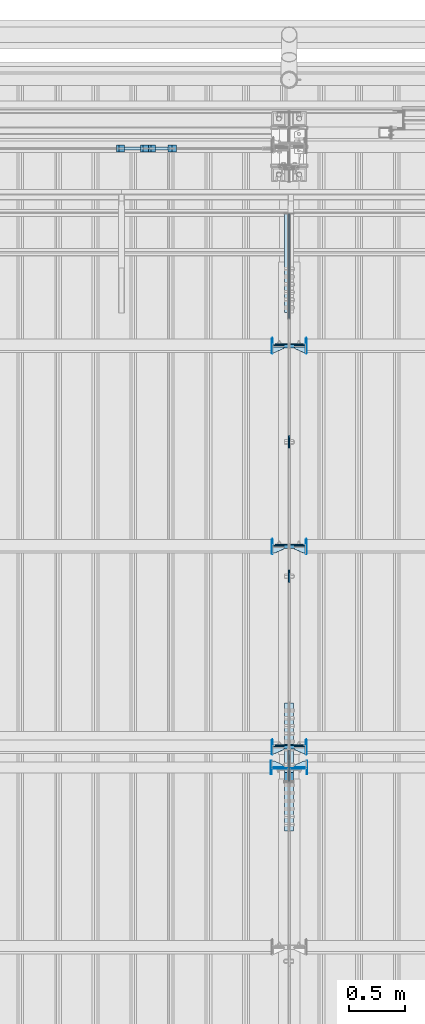
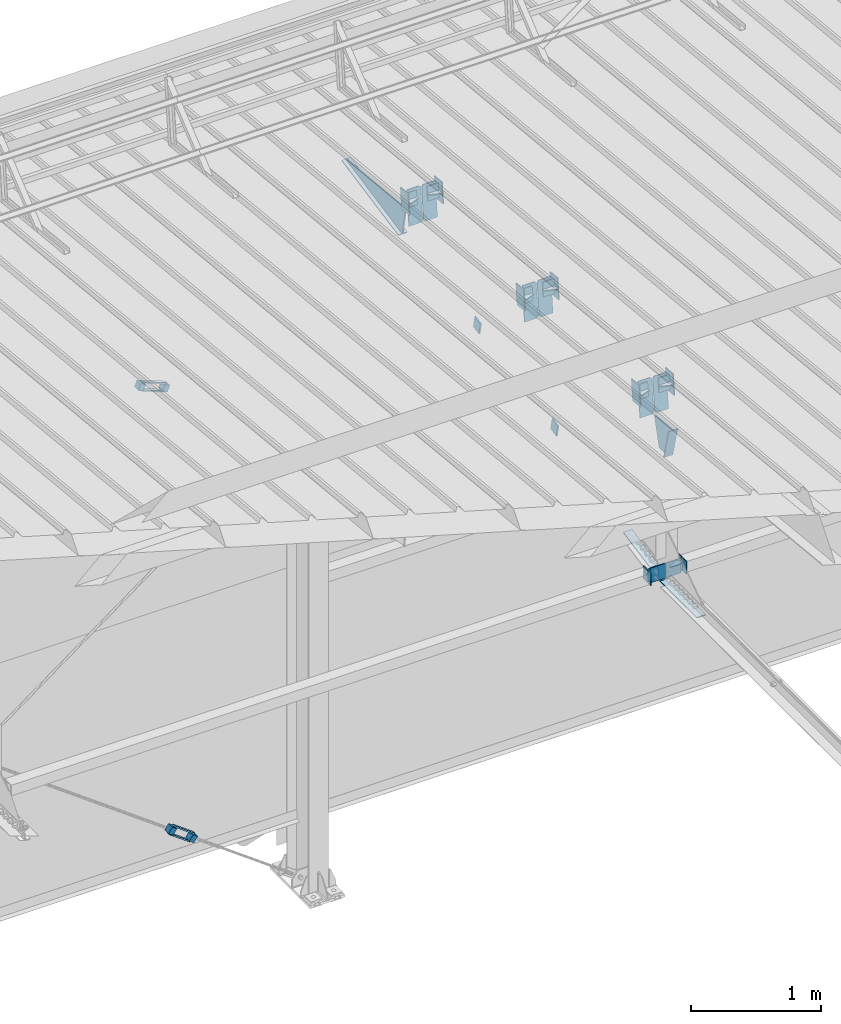
# One storey, part 141 of 709: 48 plates, 14 elements without a shape of their own.
"""IFC4 building model written with IfcOpenShell, lengths in millimetres."""

from ifc_helpers import new_model, si_unit, direction, frame, origin_with_axes, place, context, subcontext, project, spatial, line, indexed_curve, outline, extrude, material, element, aggregate, save


model = new_model("IFC4")

# Units and contexts
model_context = context("Model", 3, precision=0.2, world=origin_with_axes(), true_north=direction((0.0, 1.0)))
body_context = subcontext(model_context, "Body", "Model", "MODEL_VIEW")
ifc_project = project(units=[si_unit("LENGTHUNIT", "METRE", prefix="MILLI"), si_unit("AREAUNIT", "SQUARE_METRE"), si_unit("VOLUMEUNIT", "CUBIC_METRE"), si_unit("MASSUNIT", "GRAM", prefix="KILO"), si_unit("TIMEUNIT", "SECOND"), si_unit("PLANEANGLEUNIT", "RADIAN"), si_unit("SOLIDANGLEUNIT", "STERADIAN"), si_unit("THERMODYNAMICTEMPERATUREUNIT", "DEGREE_CELSIUS"), si_unit("LUMINOUSINTENSITYUNIT", "LUMEN")], contexts=[model_context])

# Site, building, storey
site_placement = place(None, origin_with_axes())
site = spatial("IfcSite", under=ifc_project, at=site_placement, CompositionType="ELEMENT")
building_placement = place(site_placement, origin_with_axes())
building = spatial("IfcBuilding", under=site, at=building_placement, Name="Undefined", CompositionType="ELEMENT")
storey_placement = place(building_placement, origin_with_axes())
storey = spatial("IfcBuildingStorey", under=building, at=storey_placement, Name="Undefined", CompositionType="ELEMENT", Elevation=0.0)

# Assembly, plates
assembly_1_placement = place(storey_placement, frame((28000.0, 21654.0, 7089.70002), z_axis=(-1.0, 0.0, 0.0), x_axis=(0.0, -0.9950371902, 0.099503719)))
assembly_1 = element("IfcElementAssembly", 1, at=assembly_1_placement, inside=storey)
ifc_material_1 = material(Name="C355-6", Category="STEEL")
plate_1_placement = place(assembly_1_placement, frame((1597.88359, 163.0, -127.0), z_axis=(1.0, 0.0, 0.0), x_axis=(0.0, 0.0, 1.0)))
plate_1 = element("IfcPlate", 2, at=plate_1_placement, material=ifc_material_1, ObjectType="585", context=body_context, shape_type="SolidModel", body=[
    extrude(outline(indexed_curve([(0.0, 0.0), (108.0, 0.0), (123.0, 15.0), (123.0, 311.0), (108.0, 326.0), (0.0, 326.0)], segments=[line(1, 2, 3, 4, 5, 6, 1)])), frame((0.0, 0.0, 4.0), z_axis=(0.0, 0.0, 1.0), x_axis=(1.0, 0.0, 0.0)), (0.0, 0.0, -1.0), 8.0),
])
plate_2_placement = place(assembly_1_placement, frame((1597.88359, 163.0, 127.0), z_axis=(-1.0, 0.0, 0.0), x_axis=(0.0, 0.0, -1.0)))
plate_2 = element("IfcPlate", 3, at=plate_2_placement, material=ifc_material_1, ObjectType="585", context=body_context, shape_type="SolidModel", body=[
    extrude(outline(indexed_curve([(0.0, 0.0), (108.0, 0.0), (123.0, 15.0), (123.0, 311.0), (108.0, 326.0), (0.0, 326.0)], segments=[line(1, 2, 3, 4, 5, 6, 1)])), frame((0.0, 0.0, 4.0), z_axis=(0.0, 0.0, 1.0), x_axis=(1.0, 0.0, 0.0)), (0.0, 0.0, -1.0), 8.0),
])
plate_3_placement = place(assembly_1_placement, frame((3383.44474, 163.0, -127.0), z_axis=(1.0, 0.0, 0.0), x_axis=(0.0, 0.0, 1.0)))
plate_3 = element("IfcPlate", 4, at=plate_3_placement, material=ifc_material_1, ObjectType="585", context=body_context, shape_type="SolidModel", body=[
    extrude(outline(indexed_curve([(0.0, 0.0), (108.0, 0.0), (123.0, 15.0), (123.0, 311.0), (108.0, 326.0), (0.0, 326.0)], segments=[line(1, 2, 3, 4, 5, 6, 1)])), frame((0.0, 0.0, 4.0), z_axis=(0.0, 0.0, 1.0), x_axis=(1.0, 0.0, 0.0)), (0.0, 0.0, -1.0), 8.0),
])
plate_4_placement = place(assembly_1_placement, frame((3383.44474, 163.0, 127.0), z_axis=(-1.0, 0.0, 0.0), x_axis=(0.0, 0.0, -1.0)))
plate_4 = element("IfcPlate", 5, at=plate_4_placement, material=ifc_material_1, ObjectType="585", context=body_context, shape_type="SolidModel", body=[
    extrude(outline(indexed_curve([(0.0, 0.0), (108.0, 0.0), (123.0, 15.0), (123.0, 311.0), (108.0, 326.0), (0.0, 326.0)], segments=[line(1, 2, 3, 4, 5, 6, 1)])), frame((0.0, 0.0, 4.0), z_axis=(0.0, 0.0, 1.0), x_axis=(1.0, 0.0, 0.0)), (0.0, 0.0, -1.0), 8.0),
])
plate_5_placement = place(assembly_1_placement, frame((5169.0059, 163.0, 127.0), z_axis=(-1.0, 0.0, 0.0), x_axis=(0.0, 0.0, -1.0)))
plate_5 = element("IfcPlate", 6, at=plate_5_placement, material=ifc_material_1, ObjectType="585", context=body_context, shape_type="SolidModel", body=[
    extrude(outline(indexed_curve([(0.0, 0.0), (108.0, 0.0), (123.0, 15.0), (123.0, 311.0), (108.0, 326.0), (0.0, 326.0)], segments=[line(1, 2, 3, 4, 5, 6, 1)])), frame((0.0, 0.0, 4.0), z_axis=(0.0, 0.0, 1.0), x_axis=(1.0, 0.0, 0.0)), (0.0, 0.0, -1.0), 8.0),
])
plate_6_placement = place(assembly_1_placement, frame((1336.51563, -171.28713, 0.0), z_axis=(0.0, 0.0, 1.0), x_axis=(-1.0, 0.0, 0.0)))
plate_6 = element("IfcPlate", 7, at=plate_6_placement, material=ifc_material_1, ObjectType="449", context=body_context, shape_type="SolidModel", body=[
    extrude(outline(indexed_curve([(0.0, 0.0), (928.3198, 0.0), (79.53997, 259.83056)], segments=[line(1, 2, 3, 1)])), frame((0.0, 0.0, 6.0), z_axis=(0.0, 0.0, 1.0), x_axis=(1.0, 0.0, 0.0)), (0.0, 0.0, -1.0), 12.0),
])
plate_7_placement = place(assembly_1_placement, frame((1255.8048, -434.94249, -40.0), z_axis=(0.2927142719, 0.9561999556, 0.0), x_axis=(-0.9561999556, 0.2927142719, 0.0)))
plate_7 = element("IfcPlate", 8, at=plate_7_placement, material=ifc_material_1, ObjectType="450", context=body_context, shape_type="SolidModel", body=[
    extrude(outline(indexed_curve([(0.0, 0.0), (887.65935, 0.0), (887.65935, 80.0), (0.0, 80.0)], segments=[line(1, 2, 3, 4, 1)])), frame((0.0, 0.0, 4.0), z_axis=(0.0, 0.0, 1.0), x_axis=(1.0, 0.0, 0.0)), (0.0, 0.0, -1.0), 8.0),
])
plate_8_placement = place(assembly_1_placement, frame((5223.64782, -437.93487, 0.0), z_axis=(0.0, 0.0, -1.0), x_axis=(-0.1614213634, 0.9868855777, 0.0)))
plate_8 = element("IfcPlate", 9, at=plate_8_placement, material=ifc_material_1, ObjectType="442", context=body_context, shape_type="SolidModel", body=[
    extrude(outline(indexed_curve([(0.0, 0.0), (270.19115, 0.0), (225.20717, 275.01958), (-33.64648, 125.57036)], segments=[line(1, 2, 3, 4, 1)])), frame((0.0, 0.0, 6.0), z_axis=(0.0, 0.0, 1.0), x_axis=(1.0, 0.0, 0.0)), (0.0, 0.0, -1.0), 12.0),
])
plate_9_placement = place(assembly_1_placement, frame((5462.44895, -172.70172, -40.0), z_axis=(-0.9353786626, 0.3536477874, 0.0), x_axis=(-0.3536477874, -0.9353786626, 0.0)))
plate_9 = element("IfcPlate", 10, at=plate_9_placement, material=ifc_material_1, ObjectType="443", context=body_context, shape_type="SolidModel", body=[
    extrude(outline(indexed_curve([(0.0, 0.0), (298.89845, 0.0), (298.89845, 80.0), (0.0, 80.0)], segments=[line(1, 2, 3, 4, 1)])), frame((0.0, 0.0, 4.0), z_axis=(0.0, 0.0, 1.0), x_axis=(1.0, 0.0, 0.0)), (0.0, 0.0, -1.0), 8.0),
])
plate_10_placement = place(assembly_1_placement, frame((5169.0059, 163.0, -127.0), z_axis=(1.0, 0.0, 0.0), x_axis=(0.0, 0.0, 1.0)))
plate_10 = element("IfcPlate", 11, at=plate_10_placement, material=ifc_material_1, ObjectType="585", context=body_context, shape_type="SolidModel", body=[
    extrude(outline(indexed_curve([(0.0, 0.0), (108.0, 0.0), (123.0, 15.0), (123.0, 311.0), (108.0, 326.0), (0.0, 326.0)], segments=[line(1, 2, 3, 4, 5, 6, 1)])), frame((0.0, 0.0, 4.0), z_axis=(0.0, 0.0, 1.0), x_axis=(1.0, 0.0, 0.0)), (0.0, 0.0, -1.0), 8.0),
])
aggregate(assembly_1, [plate_1, plate_2, plate_3, plate_4, plate_5, plate_6, plate_7, plate_8, plate_9, plate_10])

assembly_2_placement = place(storey_placement, frame((28000.0, 16331.38656, 5980.00002), z_axis=(-1.0, 0.0, 0.0), x_axis=(0.0, -1.0, 0.0)))
assembly_2 = element("IfcElementAssembly", 12, at=assembly_2_placement, inside=storey)
plate_11_placement = place(assembly_2_placement, frame((564.38656, -4.0, -40.0), z_axis=(0.0, 1.0, 0.0), x_axis=(-1.0, 0.0, 0.0)))
plate_11 = element("IfcPlate", 13, at=plate_11_placement, material=ifc_material_1, ObjectType="446", context=body_context, shape_type="SolidModel", body=[
    extrude(outline(indexed_curve([(0.0, 0.0), (564.38656, 0.0), (564.38656, 80.0), (0.0, 80.0)], segments=[line(1, 2, 3, 4, 1)])), frame((0.0, 0.0, 4.0), z_axis=(0.0, 0.0, 1.0), x_axis=(1.0, 0.0, 0.0)), (0.0, 0.0, -1.0), 8.0),
])
plate_12_placement = place(assembly_2_placement, frame((-569.03779, 109.72834, -40.0), z_axis=(-0.1961161349, -0.9805806757, 0.0), x_axis=(0.9805806757, -0.1961161349, 0.0)))
plate_12 = element("IfcPlate", 14, at=plate_12_placement, material=ifc_material_1, ObjectType="447", context=body_context, shape_type="SolidModel", body=[
    extrude(outline(indexed_curve([(0.0, 0.0), (579.50696, 0.0), (579.50696, 80.0), (0.0, 80.0)], segments=[line(1, 2, 3, 4, 1)])), frame((0.0, 0.0, 4.0), z_axis=(0.0, 0.0, 1.0), x_axis=(1.0, 0.0, 0.0)), (0.0, 0.0, -1.0), 8.0),
])
plate_13_placement = place(assembly_2_placement, frame((12.38656, 164.3, 134.0), z_axis=(-1.0, 0.0, 0.0), x_axis=(0.0, 0.0, -1.0)))
plate_13 = element("IfcPlate", 15, at=plate_13_placement, material=ifc_material_1, ObjectType="558", context=body_context, shape_type="SolidModel", body=[
    extrude(outline(indexed_curve([(0.0, 0.0), (130.0, 0.0), (130.0, 140.0), (0.0, 140.0)], segments=[line(1, 2, 3, 4, 1)])), frame((0.0, 0.0, 4.0), z_axis=(0.0, 0.0, 1.0), x_axis=(1.0, 0.0, 0.0)), (0.0, 0.0, -1.0), 8.0),
])
plate_14_placement = place(assembly_2_placement, frame((12.38656, 164.3, -134.0), z_axis=(1.0, 0.0, 0.0), x_axis=(0.0, 0.0, 1.0)))
plate_14 = element("IfcPlate", 16, at=plate_14_placement, material=ifc_material_1, ObjectType="558", context=body_context, shape_type="SolidModel", body=[
    extrude(outline(indexed_curve([(0.0, 0.0), (130.0, 0.0), (130.0, 140.0), (0.0, 140.0)], segments=[line(1, 2, 3, 4, 1)])), frame((0.0, 0.0, 4.0), z_axis=(0.0, 0.0, 1.0), x_axis=(1.0, 0.0, 0.0)), (0.0, 0.0, -1.0), 8.0),
])
aggregate(assembly_2, [plate_11, plate_12, plate_13, plate_14])

# Assembly, plate
assembly_3_placement = place(storey_placement, frame((28000.0, 19245.35924, 6685.17103), z_axis=(1.0, 0.0, 0.0), x_axis=(0.0, -0.9805806757, -0.1961161349)))
assembly_3 = element("IfcElementAssembly", 17, at=assembly_3_placement, inside=storey)
plate_15_placement = place(assembly_3_placement, origin_with_axes())
plate_15 = element("IfcPlate", 18, at=plate_15_placement, material=ifc_material_1, ObjectType="491", context=body_context, shape_type="SolidModel", body=[
    extrude(outline(indexed_curve([(0.0, 0.0), (90.0, 0.0), (90.0, 110.0), (0.0, 110.0)], segments=[line(1, 2, 3, 4, 1)])), frame((0.0, 0.0, 6.0), z_axis=(0.0, 0.0, 1.0), x_axis=(1.0, 0.0, 0.0)), (0.0, 0.0, -1.0), 12.0),
])
aggregate(assembly_3, [plate_15])

assembly_4_placement = place(storey_placement, frame((28000.0, 18055.82969, 6447.26512), z_axis=(1.0, 0.0, 0.0), x_axis=(0.0, -0.9805806757, -0.1961161349)))
assembly_4 = element("IfcElementAssembly", 19, at=assembly_4_placement, inside=storey)
plate_16_placement = place(assembly_4_placement, origin_with_axes())
plate_16 = element("IfcPlate", 20, at=plate_16_placement, material=ifc_material_1, ObjectType="491", context=body_context, shape_type="SolidModel", body=[
    extrude(outline(indexed_curve([(0.0, 0.0), (90.0, 0.0), (90.0, 110.0), (0.0, 110.0)], segments=[line(1, 2, 3, 4, 1)])), frame((0.0, 0.0, 6.0), z_axis=(0.0, 0.0, 1.0), x_axis=(1.0, 0.0, 0.0)), (0.0, 0.0, -1.0), 12.0),
])
aggregate(assembly_4, [plate_16])

# Assembly, plates
assembly_5_placement = place(storey_placement, frame((26795.91591, 21841.0, 764.94919), z_axis=(0.8064830392, 0.0, -0.5912572261), x_axis=(0.0, -1.0, 0.0)))
assembly_5 = element("IfcElementAssembly", 21, at=assembly_5_placement, inside=storey)
ifc_material_2 = material(Name="Steel_Undefined", Category="STEEL")
plate_17_placement = place(assembly_5_placement, origin_with_axes())
plate_17 = element("IfcPlate", 22, at=plate_17_placement, material=ifc_material_2, ObjectType="482", context=body_context, shape_type="SolidModel", body=[
    extrude(outline(indexed_curve([(0.0, 0.0), (60.0, 0.0), (60.0, 60.0), (0.0, 60.0)], segments=[line(1, 2, 3, 4, 1)])), frame((0.0, 0.0, 25.0), z_axis=(0.0, 0.0, 1.0), x_axis=(1.0, 0.0, 0.0)), (0.0, 0.0, -1.0), 50.0),
])
plate_18_placement = place(assembly_5_placement, frame((15.0, -6.0, 230.0), z_axis=(0.0, 1.0, 0.0), x_axis=(1.0, 0.0, 0.0)))
plate_18 = element("IfcPlate", 23, at=plate_18_placement, material=ifc_material_2, ObjectType="484", context=body_context, shape_type="SolidModel", body=[
    extrude(outline(indexed_curve([(0.0, 0.0), (30.0, 0.0), (30.0, 230.0), (0.0, 230.0)], segments=[line(1, 2, 3, 4, 1)])), frame((0.0, 0.0, 6.0), z_axis=(0.0, 0.0, 1.0), x_axis=(1.0, 0.0, 0.0)), (0.0, 0.0, -1.0), 12.0),
])
plate_19_placement = place(assembly_5_placement, frame((15.0, 66.0, 230.0), z_axis=(0.0, 1.0, 0.0), x_axis=(1.0, 0.0, 0.0)))
plate_19 = element("IfcPlate", 24, at=plate_19_placement, material=ifc_material_2, ObjectType="484", context=body_context, shape_type="SolidModel", body=[
    extrude(outline(indexed_curve([(0.0, 0.0), (30.0, 0.0), (30.0, 230.0), (0.0, 230.0)], segments=[line(1, 2, 3, 4, 1)])), frame((0.0, 0.0, 6.0), z_axis=(0.0, 0.0, 1.0), x_axis=(1.0, 0.0, 0.0)), (0.0, 0.0, -1.0), 12.0),
])
plate_20_placement = place(assembly_5_placement, frame((0.0, 0.0, 230.0), z_axis=(0.0, 0.0, 1.0), x_axis=(1.0, 0.0, 0.0)))
plate_20 = element("IfcPlate", 25, at=plate_20_placement, material=ifc_material_2, ObjectType="483", context=body_context, shape_type="SolidModel", body=[
    extrude(outline(indexed_curve([(0.0, 0.0), (60.0, 0.0), (60.0, 60.0), (0.0, 60.0)], segments=[line(1, 2, 3, 4, 1)])), frame((0.0, 0.0, 25.0), z_axis=(0.0, 0.0, 1.0), x_axis=(1.0, 0.0, 0.0)), (0.0, 0.0, -1.0), 50.0),
])
aggregate(assembly_5, [plate_17, plate_18, plate_19, plate_20])

assembly_6_placement = place(storey_placement, frame((26517.29313, 21841.0, 5030.02317), z_axis=(0.9286065, 0.0, -0.371065989), x_axis=(0.0, -1.0, 0.0)))
assembly_6 = element("IfcElementAssembly", 26, at=assembly_6_placement, inside=storey)
plate_21_placement = place(assembly_6_placement, frame((15.0, 66.0, 230.0), z_axis=(0.0, 1.0, 0.0), x_axis=(1.0, 0.0, 0.0)))
plate_21 = element("IfcPlate", 27, at=plate_21_placement, material=ifc_material_2, ObjectType="484", context=body_context, shape_type="SolidModel", body=[
    extrude(outline(indexed_curve([(0.0, 0.0), (30.0, 0.0), (30.0, 230.0), (0.0, 230.0)], segments=[line(1, 2, 3, 4, 1)])), frame((0.0, 0.0, 6.0), z_axis=(0.0, 0.0, 1.0), x_axis=(1.0, 0.0, 0.0)), (0.0, 0.0, -1.0), 12.0),
])
plate_22_placement = place(assembly_6_placement, frame((15.0, -6.0, 230.0), z_axis=(0.0, 1.0, 0.0), x_axis=(1.0, 0.0, 0.0)))
plate_22 = element("IfcPlate", 28, at=plate_22_placement, material=ifc_material_2, ObjectType="484", context=body_context, shape_type="SolidModel", body=[
    extrude(outline(indexed_curve([(0.0, 0.0), (30.0, 0.0), (30.0, 230.0), (0.0, 230.0)], segments=[line(1, 2, 3, 4, 1)])), frame((0.0, 0.0, 6.0), z_axis=(0.0, 0.0, 1.0), x_axis=(1.0, 0.0, 0.0)), (0.0, 0.0, -1.0), 12.0),
])
plate_23_placement = place(assembly_6_placement, origin_with_axes())
plate_23 = element("IfcPlate", 29, at=plate_23_placement, material=ifc_material_2, ObjectType="482", context=body_context, shape_type="SolidModel", body=[
    extrude(outline(indexed_curve([(0.0, 0.0), (60.0, 0.0), (60.0, 60.0), (0.0, 60.0)], segments=[line(1, 2, 3, 4, 1)])), frame((0.0, 0.0, 25.0), z_axis=(0.0, 0.0, 1.0), x_axis=(1.0, 0.0, 0.0)), (0.0, 0.0, -1.0), 50.0),
])
plate_24_placement = place(assembly_6_placement, frame((0.0, 0.0, 230.0), z_axis=(0.0, 0.0, 1.0), x_axis=(1.0, 0.0, 0.0)))
plate_24 = element("IfcPlate", 30, at=plate_24_placement, material=ifc_material_2, ObjectType="483", context=body_context, shape_type="SolidModel", body=[
    extrude(outline(indexed_curve([(0.0, 0.0), (60.0, 0.0), (60.0, 60.0), (0.0, 60.0)], segments=[line(1, 2, 3, 4, 1)])), frame((0.0, 0.0, 25.0), z_axis=(0.0, 0.0, 1.0), x_axis=(1.0, 0.0, 0.0)), (0.0, 0.0, -1.0), 50.0),
])
aggregate(assembly_6, [plate_21, plate_22, plate_23, plate_24])

assembly_7_placement = place(storey_placement, frame((22000.0, 16327.0, 6074.30002), z_axis=(0.0, -1.0, 0.0), x_axis=(1.0, 0.0, 0.0)))
assembly_7 = element("IfcElementAssembly", 31, at=assembly_7_placement, inside=storey)
plate_25_placement = place(assembly_7_placement, frame((5842.0, -60.0, 60.0), z_axis=(1.0, 0.0, 0.0), x_axis=(0.0, 0.0, -1.0)))
plate_25 = element("IfcPlate", 32, at=plate_25_placement, material=ifc_material_1, ObjectType="559", context=body_context, shape_type="SolidModel", body=[
    extrude(outline(indexed_curve([(0.0, 0.0), (120.0, 0.0), (120.0, 120.0), (0.0, 120.0)], segments=[line(1, 2, 3, 4, 1)])), frame((0.0, 0.0, 4.0), z_axis=(0.0, 0.0, 1.0), x_axis=(1.0, 0.0, 0.0)), (0.0, 0.0, -1.0), 8.0),
])
plate_26_placement = place(assembly_7_placement, frame((5946.0, -60.0, 0.0), z_axis=(0.0, 0.0, 1.0), x_axis=(0.0, 1.0, 0.0)))
plate_26 = element("IfcPlate", 33, at=plate_26_placement, material=ifc_material_1, ObjectType="560", context=body_context, shape_type="SolidModel", body=[
    extrude(outline(indexed_curve([(0.0, 0.0), (120.0, 0.0), (120.0, 100.0), (0.0, 100.0)], segments=[line(1, 2, 3, 4, 1)])), frame((0.0, 0.0, 4.0), z_axis=(0.0, 0.0, 1.0), x_axis=(1.0, 0.0, 0.0)), (0.0, 0.0, -1.0), 8.0),
])
plate_27_placement = place(assembly_7_placement, frame((5946.0, 0.0, -60.0), z_axis=(0.0, -1.0, 0.0), x_axis=(0.0, 0.0, 1.0)))
plate_27 = element("IfcPlate", 34, at=plate_27_placement, material=ifc_material_1, ObjectType="561", context=body_context, shape_type="SolidModel", body=[
    extrude(outline(indexed_curve([(0.0, 80.0), (36.0, 0.0), (56.0, 0.0), (56.0, 90.0), (46.0, 100.0), (0.0, 100.0)], segments=[line(1, 2, 3, 4, 5, 6, 1)])), frame((0.0, 0.0, 4.0), z_axis=(0.0, 0.0, 1.0), x_axis=(1.0, 0.0, 0.0)), (0.0, 0.0, -1.0), 8.0),
])
aggregate(assembly_7, [plate_25, plate_26, plate_27])

assembly_8_placement = place(storey_placement, frame((28000.0, 16327.0, 6074.30002), z_axis=(0.0, -1.0, 0.0), x_axis=(1.0, 0.0, 0.0)))
assembly_8 = element("IfcElementAssembly", 35, at=assembly_8_placement, inside=storey)
plate_28_placement = place(assembly_8_placement, frame((158.0, 60.0, 60.0), z_axis=(-1.0, 0.0, 0.0), x_axis=(0.0, 0.0, -1.0)))
plate_28 = element("IfcPlate", 36, at=plate_28_placement, material=ifc_material_1, ObjectType="559", context=body_context, shape_type="SolidModel", body=[
    extrude(outline(indexed_curve([(0.0, 0.0), (120.0, 0.0), (120.0, 120.0), (0.0, 120.0)], segments=[line(1, 2, 3, 4, 1)])), frame((0.0, 0.0, 4.0), z_axis=(0.0, 0.0, 1.0), x_axis=(1.0, 0.0, 0.0)), (0.0, 0.0, -1.0), 8.0),
])
plate_29_placement = place(assembly_8_placement, frame((54.0, 60.0, 0.0), z_axis=(0.0, 0.0, 1.0), x_axis=(0.0, -1.0, 0.0)))
plate_29 = element("IfcPlate", 37, at=plate_29_placement, material=ifc_material_1, ObjectType="560", context=body_context, shape_type="SolidModel", body=[
    extrude(outline(indexed_curve([(0.0, 0.0), (120.0, 0.0), (120.0, 100.0), (0.0, 100.0)], segments=[line(1, 2, 3, 4, 1)])), frame((0.0, 0.0, 4.0), z_axis=(0.0, 0.0, 1.0), x_axis=(1.0, 0.0, 0.0)), (0.0, 0.0, -1.0), 8.0),
])
plate_30_placement = place(assembly_8_placement, frame((54.0, 0.0, -60.0), z_axis=(0.0, 1.0, 0.0), x_axis=(0.0, 0.0, 1.0)))
plate_30 = element("IfcPlate", 38, at=plate_30_placement, material=ifc_material_1, ObjectType="561", context=body_context, shape_type="SolidModel", body=[
    extrude(outline(indexed_curve([(0.0, 80.0), (36.0, 0.0), (56.0, 0.0), (56.0, 90.0), (46.0, 100.0), (0.0, 100.0)], segments=[line(1, 2, 3, 4, 5, 6, 1)])), frame((0.0, 0.0, 4.0), z_axis=(0.0, 0.0, 1.0), x_axis=(1.0, 0.0, 0.0)), (0.0, 0.0, -1.0), 8.0),
])
aggregate(assembly_8, [plate_28, plate_29, plate_30])

assembly_9_placement = place(storey_placement, frame((28000.0, 16509.95037, 7677.46908), z_axis=(0.0, -0.9950371902, 0.099503719), x_axis=(-1.0, 0.0, 0.0)))
assembly_9 = element("IfcElementAssembly", 39, at=assembly_9_placement, inside=storey)
plate_31_placement = place(assembly_9_placement, frame((47.0, -65.0, 0.0), z_axis=(0.0, 0.0, 1.0), x_axis=(1.0, 0.0, 0.0)))
plate_31 = element("IfcPlate", 40, at=plate_31_placement, material=ifc_material_1, ObjectType="587", context=body_context, shape_type="SolidModel", body=[
    extrude(outline(indexed_curve([(0.0, 0.0), (100.0, 0.0), (100.0, 130.0), (0.0, 130.0)], segments=[line(1, 2, 3, 4, 1)])), frame((0.0, 0.0, 4.0), z_axis=(0.0, 0.0, 1.0), x_axis=(1.0, 0.0, 0.0)), (0.0, 0.0, -1.0), 8.0),
])
plate_32_placement = place(assembly_9_placement, frame((47.0, 0.0, 60.0), z_axis=(0.0, 1.0, 0.0), x_axis=(1.0, 0.0, 0.0)))
plate_32 = element("IfcPlate", 41, at=plate_32_placement, material=ifc_material_1, ObjectType="588", context=body_context, shape_type="SolidModel", body=[
    extrude(outline(indexed_curve([(0.0, 36.0), (80.0, 0.0), (100.0, 0.0), (100.0, 56.0), (0.0, 56.0)], segments=[line(1, 2, 3, 4, 5, 1)])), frame((0.0, 0.0, 4.0), z_axis=(0.0, 0.0, 1.0), x_axis=(1.0, 0.0, 0.0)), (0.0, 0.0, -1.0), 8.0),
])
plate_33_placement = place(assembly_9_placement, frame((151.0, -98.0, -60.0), z_axis=(-1.0, 0.0, 0.0), x_axis=(0.0, 0.0, 1.0)))
plate_33 = element("IfcPlate", 42, at=plate_33_placement, material=ifc_material_1, ObjectType="586", context=body_context, shape_type="SolidModel", body=[
    extrude(outline(indexed_curve([(0.0, 0.0), (120.0, 0.0), (120.0, 196.0), (0.0, 196.0)], segments=[line(1, 2, 3, 4, 1)])), frame((0.0, 0.0, 4.0), z_axis=(0.0, 0.0, 1.0), x_axis=(1.0, 0.0, 0.0)), (0.0, 0.0, -1.0), 8.0),
])
aggregate(assembly_9, [plate_31, plate_32, plate_33])

assembly_10_placement = place(storey_placement, frame((28000.0, 18286.65012, 7499.7991), z_axis=(0.0, -0.9950371902, 0.099503719), x_axis=(-1.0, 0.0, 0.0)))
assembly_10 = element("IfcElementAssembly", 43, at=assembly_10_placement, inside=storey)
plate_34_placement = place(assembly_10_placement, frame((47.0, 0.0, 60.0), z_axis=(0.0, 1.0, 0.0), x_axis=(1.0, 0.0, 0.0)))
plate_34 = element("IfcPlate", 44, at=plate_34_placement, material=ifc_material_1, ObjectType="588", context=body_context, shape_type="SolidModel", body=[
    extrude(outline(indexed_curve([(0.0, 36.0), (80.0, 0.0), (100.0, 0.0), (100.0, 56.0), (0.0, 56.0)], segments=[line(1, 2, 3, 4, 5, 1)])), frame((0.0, 0.0, 4.0), z_axis=(0.0, 0.0, 1.0), x_axis=(1.0, 0.0, 0.0)), (0.0, 0.0, -1.0), 8.0),
])
plate_35_placement = place(assembly_10_placement, frame((47.0, -65.0, 0.0), z_axis=(0.0, 0.0, 1.0), x_axis=(1.0, 0.0, 0.0)))
plate_35 = element("IfcPlate", 45, at=plate_35_placement, material=ifc_material_1, ObjectType="587", context=body_context, shape_type="SolidModel", body=[
    extrude(outline(indexed_curve([(0.0, 0.0), (100.0, 0.0), (100.0, 130.0), (0.0, 130.0)], segments=[line(1, 2, 3, 4, 1)])), frame((0.0, 0.0, 4.0), z_axis=(0.0, 0.0, 1.0), x_axis=(1.0, 0.0, 0.0)), (0.0, 0.0, -1.0), 8.0),
])
plate_36_placement = place(assembly_10_placement, frame((151.0, -98.0, -60.0), z_axis=(-1.0, 0.0, 0.0), x_axis=(0.0, 0.0, 1.0)))
plate_36 = element("IfcPlate", 46, at=plate_36_placement, material=ifc_material_1, ObjectType="586", context=body_context, shape_type="SolidModel", body=[
    extrude(outline(indexed_curve([(0.0, 0.0), (120.0, 0.0), (120.0, 196.0), (0.0, 196.0)], segments=[line(1, 2, 3, 4, 1)])), frame((0.0, 0.0, 4.0), z_axis=(0.0, 0.0, 1.0), x_axis=(1.0, 0.0, 0.0)), (0.0, 0.0, -1.0), 8.0),
])
aggregate(assembly_10, [plate_34, plate_35, plate_36])

assembly_11_placement = place(storey_placement, frame((28000.0, 20063.34988, 7322.12913), z_axis=(0.0, -0.9950371902, 0.099503719), x_axis=(-1.0, 0.0, 0.0)))
assembly_11 = element("IfcElementAssembly", 47, at=assembly_11_placement, inside=storey)
plate_37_placement = place(assembly_11_placement, frame((47.0, 0.0, 60.0), z_axis=(0.0, 1.0, 0.0), x_axis=(1.0, 0.0, 0.0)))
plate_37 = element("IfcPlate", 48, at=plate_37_placement, material=ifc_material_1, ObjectType="588", context=body_context, shape_type="SolidModel", body=[
    extrude(outline(indexed_curve([(0.0, 36.0), (80.0, 0.0), (100.0, 0.0), (100.0, 56.0), (0.0, 56.0)], segments=[line(1, 2, 3, 4, 5, 1)])), frame((0.0, 0.0, 4.0), z_axis=(0.0, 0.0, 1.0), x_axis=(1.0, 0.0, 0.0)), (0.0, 0.0, -1.0), 8.0),
])
plate_38_placement = place(assembly_11_placement, frame((151.0, -98.0, -60.0), z_axis=(-1.0, 0.0, 0.0), x_axis=(0.0, 0.0, 1.0)))
plate_38 = element("IfcPlate", 49, at=plate_38_placement, material=ifc_material_1, ObjectType="586", context=body_context, shape_type="SolidModel", body=[
    extrude(outline(indexed_curve([(0.0, 0.0), (120.0, 0.0), (120.0, 196.0), (0.0, 196.0)], segments=[line(1, 2, 3, 4, 1)])), frame((0.0, 0.0, 4.0), z_axis=(0.0, 0.0, 1.0), x_axis=(1.0, 0.0, 0.0)), (0.0, 0.0, -1.0), 8.0),
])
plate_39_placement = place(assembly_11_placement, frame((47.0, -65.0, 0.0), z_axis=(0.0, 0.0, 1.0), x_axis=(1.0, 0.0, 0.0)))
plate_39 = element("IfcPlate", 50, at=plate_39_placement, material=ifc_material_1, ObjectType="587", context=body_context, shape_type="SolidModel", body=[
    extrude(outline(indexed_curve([(0.0, 0.0), (100.0, 0.0), (100.0, 130.0), (0.0, 130.0)], segments=[line(1, 2, 3, 4, 1)])), frame((0.0, 0.0, 4.0), z_axis=(0.0, 0.0, 1.0), x_axis=(1.0, 0.0, 0.0)), (0.0, 0.0, -1.0), 8.0),
])
aggregate(assembly_11, [plate_37, plate_38, plate_39])

assembly_12_placement = place(storey_placement, frame((34000.0, 16509.95037, 7677.46908), z_axis=(0.0, -0.9950371902, 0.099503719), x_axis=(-1.0, 0.0, 0.0)))
assembly_12 = element("IfcElementAssembly", 51, at=assembly_12_placement, inside=storey)
plate_40_placement = place(assembly_12_placement, frame((5849.0, -98.0, 60.0), z_axis=(1.0, 0.0, 0.0), x_axis=(0.0, 0.0, -1.0)))
plate_40 = element("IfcPlate", 52, at=plate_40_placement, material=ifc_material_1, ObjectType="586", context=body_context, shape_type="SolidModel", body=[
    extrude(outline(indexed_curve([(0.0, 0.0), (120.0, 0.0), (120.0, 196.0), (0.0, 196.0)], segments=[line(1, 2, 3, 4, 1)])), frame((0.0, 0.0, 4.0), z_axis=(0.0, 0.0, 1.0), x_axis=(1.0, 0.0, 0.0)), (0.0, 0.0, -1.0), 8.0),
])
plate_41_placement = place(assembly_12_placement, frame((5953.0, 0.0, 60.0), z_axis=(0.0, -1.0, 0.0), x_axis=(-1.0, 0.0, 0.0)))
plate_41 = element("IfcPlate", 53, at=plate_41_placement, material=ifc_material_1, ObjectType="588", context=body_context, shape_type="SolidModel", body=[
    extrude(outline(indexed_curve([(0.0, 36.0), (80.0, 0.0), (100.0, 0.0), (100.0, 56.0), (0.0, 56.0)], segments=[line(1, 2, 3, 4, 5, 1)])), frame((0.0, 0.0, 4.0), z_axis=(0.0, 0.0, 1.0), x_axis=(1.0, 0.0, 0.0)), (0.0, 0.0, -1.0), 8.0),
])
plate_42_placement = place(assembly_12_placement, frame((5953.0, 65.0, 0.0), z_axis=(0.0, 0.0, 1.0), x_axis=(-1.0, 0.0, 0.0)))
plate_42 = element("IfcPlate", 54, at=plate_42_placement, material=ifc_material_1, ObjectType="587", context=body_context, shape_type="SolidModel", body=[
    extrude(outline(indexed_curve([(0.0, 0.0), (100.0, 0.0), (100.0, 130.0), (0.0, 130.0)], segments=[line(1, 2, 3, 4, 1)])), frame((0.0, 0.0, 4.0), z_axis=(0.0, 0.0, 1.0), x_axis=(1.0, 0.0, 0.0)), (0.0, 0.0, -1.0), 8.0),
])
aggregate(assembly_12, [plate_40, plate_41, plate_42])

assembly_13_placement = place(storey_placement, frame((34000.0, 18286.65012, 7499.7991), z_axis=(0.0, -0.9950371902, 0.099503719), x_axis=(-1.0, 0.0, 0.0)))
assembly_13 = element("IfcElementAssembly", 55, at=assembly_13_placement, inside=storey)
plate_43_placement = place(assembly_13_placement, frame((5953.0, 0.0, 60.0), z_axis=(0.0, -1.0, 0.0), x_axis=(-1.0, 0.0, 0.0)))
plate_43 = element("IfcPlate", 56, at=plate_43_placement, material=ifc_material_1, ObjectType="588", context=body_context, shape_type="SolidModel", body=[
    extrude(outline(indexed_curve([(0.0, 36.0), (80.0, 0.0), (100.0, 0.0), (100.0, 56.0), (0.0, 56.0)], segments=[line(1, 2, 3, 4, 5, 1)])), frame((0.0, 0.0, 4.0), z_axis=(0.0, 0.0, 1.0), x_axis=(1.0, 0.0, 0.0)), (0.0, 0.0, -1.0), 8.0),
])
plate_44_placement = place(assembly_13_placement, frame((5953.0, 65.0, 0.0), z_axis=(0.0, 0.0, 1.0), x_axis=(-1.0, 0.0, 0.0)))
plate_44 = element("IfcPlate", 57, at=plate_44_placement, material=ifc_material_1, ObjectType="587", context=body_context, shape_type="SolidModel", body=[
    extrude(outline(indexed_curve([(0.0, 0.0), (100.0, 0.0), (100.0, 130.0), (0.0, 130.0)], segments=[line(1, 2, 3, 4, 1)])), frame((0.0, 0.0, 4.0), z_axis=(0.0, 0.0, 1.0), x_axis=(1.0, 0.0, 0.0)), (0.0, 0.0, -1.0), 8.0),
])
plate_45_placement = place(assembly_13_placement, frame((5849.0, -98.0, 60.0), z_axis=(1.0, 0.0, 0.0), x_axis=(0.0, 0.0, -1.0)))
plate_45 = element("IfcPlate", 58, at=plate_45_placement, material=ifc_material_1, ObjectType="586", context=body_context, shape_type="SolidModel", body=[
    extrude(outline(indexed_curve([(0.0, 0.0), (120.0, 0.0), (120.0, 196.0), (0.0, 196.0)], segments=[line(1, 2, 3, 4, 1)])), frame((0.0, 0.0, 4.0), z_axis=(0.0, 0.0, 1.0), x_axis=(1.0, 0.0, 0.0)), (0.0, 0.0, -1.0), 8.0),
])
aggregate(assembly_13, [plate_43, plate_44, plate_45])

assembly_14_placement = place(storey_placement, frame((34000.0, 20063.34988, 7322.12913), z_axis=(0.0, -0.9950371902, 0.099503719), x_axis=(-1.0, 0.0, 0.0)))
assembly_14 = element("IfcElementAssembly", 59, at=assembly_14_placement, inside=storey)
plate_46_placement = place(assembly_14_placement, frame((5953.0, 65.0, 0.0), z_axis=(0.0, 0.0, 1.0), x_axis=(-1.0, 0.0, 0.0)))
plate_46 = element("IfcPlate", 60, at=plate_46_placement, material=ifc_material_1, ObjectType="587", context=body_context, shape_type="SolidModel", body=[
    extrude(outline(indexed_curve([(0.0, 0.0), (100.0, 0.0), (100.0, 130.0), (0.0, 130.0)], segments=[line(1, 2, 3, 4, 1)])), frame((0.0, 0.0, 4.0), z_axis=(0.0, 0.0, 1.0), x_axis=(1.0, 0.0, 0.0)), (0.0, 0.0, -1.0), 8.0),
])
plate_47_placement = place(assembly_14_placement, frame((5953.0, 0.0, 60.0), z_axis=(0.0, -1.0, 0.0), x_axis=(-1.0, 0.0, 0.0)))
plate_47 = element("IfcPlate", 61, at=plate_47_placement, material=ifc_material_1, ObjectType="588", context=body_context, shape_type="SolidModel", body=[
    extrude(outline(indexed_curve([(0.0, 36.0), (80.0, 0.0), (100.0, 0.0), (100.0, 56.0), (0.0, 56.0)], segments=[line(1, 2, 3, 4, 5, 1)])), frame((0.0, 0.0, 4.0), z_axis=(0.0, 0.0, 1.0), x_axis=(1.0, 0.0, 0.0)), (0.0, 0.0, -1.0), 8.0),
])
plate_48_placement = place(assembly_14_placement, frame((5849.0, -98.0, 60.0), z_axis=(1.0, 0.0, 0.0), x_axis=(0.0, 0.0, -1.0)))
plate_48 = element("IfcPlate", 62, at=plate_48_placement, material=ifc_material_1, ObjectType="586", context=body_context, shape_type="SolidModel", body=[
    extrude(outline(indexed_curve([(0.0, 0.0), (120.0, 0.0), (120.0, 196.0), (0.0, 196.0)], segments=[line(1, 2, 3, 4, 1)])), frame((0.0, 0.0, 4.0), z_axis=(0.0, 0.0, 1.0), x_axis=(1.0, 0.0, 0.0)), (0.0, 0.0, -1.0), 8.0),
])
aggregate(assembly_14, [plate_46, plate_47, plate_48])

save(model, "model.ifc")
